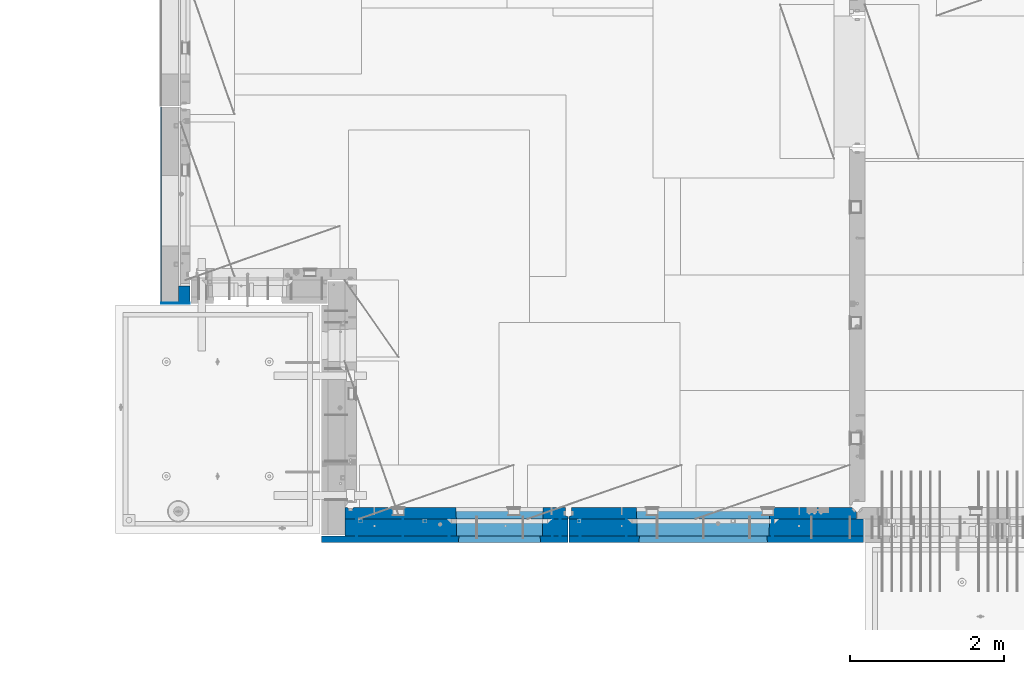
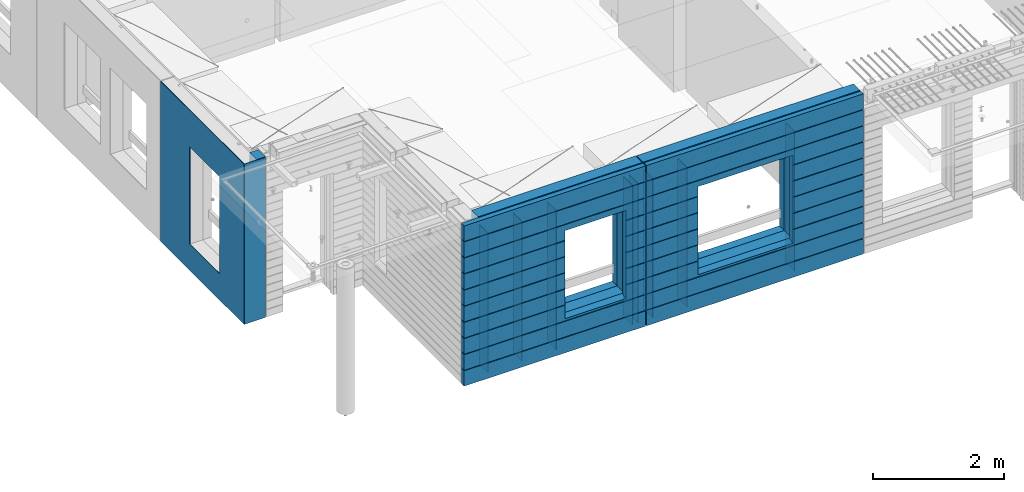
# One storey, part 216 of 334: 17 walls, 3 elements without a shape of their own.
"""IFC2X3 building model written with IfcOpenShell, lengths in millimetres."""

from ifc_helpers import new_model, si_unit, frame, origin_with_axes, place, context, subcontext, project, spatial, faceted_brep, material, type_object, element, aggregate, save


model = new_model("IFC2X3")

# Units and contexts
model_context = context("Model", 3, precision=1e-05, world=origin_with_axes())
body_context = subcontext(model_context, "Body", "Model", "MODEL_VIEW")
ifc_project = project(units=[si_unit("LENGTHUNIT", "METRE", prefix="MILLI"), si_unit("AREAUNIT", "SQUARE_METRE"), si_unit("VOLUMEUNIT", "CUBIC_METRE"), si_unit("MASSUNIT", "GRAM", prefix="KILO"), si_unit("TIMEUNIT", "SECOND"), si_unit("PLANEANGLEUNIT", "RADIAN"), si_unit("SOLIDANGLEUNIT", "STERADIAN"), si_unit("THERMODYNAMICTEMPERATUREUNIT", "DEGREE_CELSIUS"), si_unit("LUMINOUSINTENSITYUNIT", "LUMEN")], contexts=[model_context])

# Site, building, storey
site_placement = place(None, origin_with_axes())
site = spatial("IfcSite", under=ifc_project, at=site_placement, CompositionType="ELEMENT")
building_placement = place(site_placement, origin_with_axes())
building = spatial("IfcBuilding", under=site, at=building_placement, CompositionType="ELEMENT")
storey_placement = place(building_placement, origin_with_axes())
storey = spatial("IfcBuildingStorey", under=building, at=storey_placement, Name="3", CompositionType="ELEMENT", Elevation=0.0)

# Assembly, walls
assembly_1_placement = place(storey_placement, origin_with_axes())
assembly_1 = element("IfcElementAssembly", 1, at=assembly_1_placement, inside=storey, AssemblyPlace="NOTDEFINED", PredefinedType="REINFORCEMENT_UNIT")
ifc_material_1 = material(Name="Undefined")
wall_type_1 = type_object("IfcWallType", PredefinedType="NOTDEFINED")
wall_1_placement = place(assembly_1_placement, frame((10165.0, 7880.0, 89115.0), z_axis=(0.0, 0.0, 1.0), x_axis=(0.0, -1.0, 0.0)))
wall_1 = element("IfcWall", 2, at=wall_1_placement, type_object=wall_type_1, material=ifc_material_1, Name="(PD)", context=body_context, shape_type="Brep", body=[
    faceted_brep([(0.0, 5.0, -1300.0), (0.0, 5.0, 1300.0), (280.0, 5.0, 1300.0), (280.0, 5.0, -1300.0), (0.0, -5.0, 1300.0), (280.0, -5.0, 1300.0), (0.0, -5.0, -1300.0), (280.0, -5.0, -1300.0)], [[[0, 1, 2, 3]], [[1, 4, 5, 2]], [[4, 6, 7, 5]], [[6, 0, 3, 7]], [[5, 7, 3, 2]], [[6, 4, 1, 0]]]),
])
wall_2_placement = place(assembly_1_placement, frame((10765.0, 7880.0, 89115.0), z_axis=(0.0, 0.0, 1.0), x_axis=(0.0, -1.0, 0.0)))
wall_2 = element("IfcWall", 3, at=wall_2_placement, type_object=wall_type_1, material=ifc_material_1, Name="(PD)", context=body_context, shape_type="Brep", body=[
    faceted_brep([(0.0, 5.0, -1300.0), (0.0, 5.0, 1300.0), (280.0, 5.0, 1300.0), (280.0, 5.0, -1300.0), (0.0, -5.0, 1300.0), (280.0, -5.0, 1300.0), (0.0, -5.0, -1300.0), (280.0, -5.0, -1300.0)], [[[0, 1, 2, 3]], [[1, 4, 5, 2]], [[4, 6, 7, 5]], [[6, 0, 3, 7]], [[5, 7, 3, 2]], [[6, 4, 1, 0]]]),
])
wall_3_placement = place(assembly_1_placement, frame((12705.0, 7880.0, 89115.0), z_axis=(0.0, 0.0, 1.0), x_axis=(0.0, -1.0, 0.0)))
wall_3 = element("IfcWall", 4, at=wall_3_placement, type_object=wall_type_1, material=ifc_material_1, Name="(PD)", context=body_context, shape_type="Brep", body=[
    faceted_brep([(0.0, 5.0, -1300.0), (0.0, 5.0, 1300.0), (280.0, 5.0, 1300.0), (280.0, 5.0, -1300.0), (0.0, -5.0, 1300.0), (280.0, -5.0, 1300.0), (0.0, -5.0, -1300.0), (280.0, -5.0, -1300.0)], [[[0, 1, 2, 3]], [[1, 4, 5, 2]], [[4, 6, 7, 5]], [[6, 0, 3, 7]], [[5, 7, 3, 2]], [[6, 4, 1, 0]]]),
])

assembly_2_placement = place(storey_placement, origin_with_axes())
assembly_2 = element("IfcElementAssembly", 5, at=assembly_2_placement, inside=storey, AssemblyPlace="NOTDEFINED", PredefinedType="REINFORCEMENT_UNIT")
wall_4_placement = place(assembly_2_placement, frame((13665.0, 7880.0, 89115.0), z_axis=(0.0, 0.0, 1.0), x_axis=(0.0, -1.0, 0.0)))
wall_4 = element("IfcWall", 6, at=wall_4_placement, type_object=wall_type_1, material=ifc_material_1, Name="(PD)", context=body_context, shape_type="Brep", body=[
    faceted_brep([(0.0, 5.0, -1300.0), (0.0, 5.0, 1300.0), (280.0, 5.0, 1300.0), (280.0, 5.0, -1300.0), (0.0, -5.0, 1300.0), (280.0, -5.0, 1300.0), (0.0, -5.0, -1300.0), (280.0, -5.0, -1300.0)], [[[0, 1, 2, 3]], [[1, 4, 5, 2]], [[4, 6, 7, 5]], [[6, 0, 3, 7]], [[5, 7, 3, 2]], [[6, 4, 1, 0]]]),
])
wall_5_placement = place(assembly_2_placement, frame((13065.0, 7880.0, 89115.0), z_axis=(0.0, 0.0, 1.0), x_axis=(0.0, -1.0, 0.0)))
wall_5 = element("IfcWall", 7, at=wall_5_placement, type_object=wall_type_1, material=ifc_material_1, Name="(PD)", context=body_context, shape_type="Brep", body=[
    faceted_brep([(0.0, 5.0, -1300.0), (0.0, 5.0, 1300.0), (280.0, 5.0, 1300.0), (280.0, 5.0, -1300.0), (0.0, -5.0, 1300.0), (280.0, -5.0, 1300.0), (0.0, -5.0, -1300.0), (280.0, -5.0, -1300.0)], [[[0, 1, 2, 3]], [[1, 4, 5, 2]], [[4, 6, 7, 5]], [[6, 0, 3, 7]], [[5, 7, 3, 2]], [[6, 4, 1, 0]]]),
])
wall_6_placement = place(assembly_2_placement, frame((15565.0, 7880.0, 89115.0), z_axis=(0.0, 0.0, 1.0), x_axis=(0.0, -1.0, 0.0)))
wall_6 = element("IfcWall", 8, at=wall_6_placement, type_object=wall_type_1, material=ifc_material_1, Name="(PD)", context=body_context, shape_type="Brep", body=[
    faceted_brep([(0.0, 5.0, -1300.0), (0.0, 5.0, 1300.0), (280.0, 5.0, 1300.0), (280.0, 5.0, -1300.0), (0.0, -5.0, 1300.0), (280.0, -5.0, 1300.0), (0.0, -5.0, -1300.0), (280.0, -5.0, -1300.0)], [[[0, 1, 2, 3]], [[1, 4, 5, 2]], [[4, 6, 7, 5]], [[6, 0, 3, 7]], [[5, 7, 3, 2]], [[6, 4, 1, 0]]]),
])

# Wall
wall_7_placement = place(assembly_1_placement, frame((12805.0, 7880.0, 89115.0), z_axis=(0.0, 0.0, 1.0), x_axis=(0.0, -1.0, 0.0)))
wall_7 = element("IfcWall", 9, at=wall_7_placement, type_object=wall_type_1, material=ifc_material_1, Name="(PD)", context=body_context, shape_type="Brep", body=[
    faceted_brep([(0.0, 5.0, -1300.0), (0.0, 5.0, 1300.0), (280.0, 5.0, 1300.0), (280.0, 5.0, -1300.0), (0.0, -5.0, 1300.0), (280.0, -5.0, 1300.0), (0.0, -5.0, -1300.0), (280.0, -5.0, -1300.0)], [[[0, 1, 2, 3]], [[1, 4, 5, 2]], [[4, 6, 7, 5]], [[6, 0, 3, 7]], [[5, 7, 3, 2]], [[6, 4, 1, 0]]]),
])

wall_8_placement = place(assembly_1_placement, frame((11365.0, 7880.0, 89115.0), z_axis=(0.0, 0.0, 1.0), x_axis=(0.0, -1.0, 0.0)))
wall_8 = element("IfcWall", 10, at=wall_8_placement, type_object=wall_type_1, material=ifc_material_1, Name="(PD)", context=body_context, shape_type="Brep", body=[
    faceted_brep([(0.0, 5.0, -1300.0), (0.0, 5.0, 1300.0), (280.0, 5.0, 1300.0), (280.0, 5.0, -1300.0), (0.0, -5.0, 1300.0), (280.0, -5.0, 1300.0), (0.0, -5.0, -1300.0), (280.0, -5.0, -1300.0)], [[[0, 1, 2, 3]], [[1, 4, 5, 2]], [[4, 6, 7, 5]], [[6, 0, 3, 7]], [[5, 7, 3, 2]], [[6, 4, 1, 0]]]),
])

# Assembly, wall
assembly_3_placement = place(storey_placement, origin_with_axes())
assembly_3 = element("IfcElementAssembly", 11, at=assembly_3_placement, inside=storey, AssemblyPlace="NOTDEFINED", PredefinedType="REINFORCEMENT_UNIT")
ifc_material_2 = material()
wall_type_2 = type_object("IfcWallType", PredefinedType="NOTDEFINED")
wall_9_placement = place(assembly_3_placement, frame((8000.00051558999, 10765.0000158944, 89247.5), z_axis=(0.0, 0.0, 1.0), x_axis=(-0.999999999997437, -2.26400000064461e-06, 0.0)))
wall_9 = element("IfcWall", 12, at=wall_9_placement, type_object=wall_type_2, material=ifc_material_2, context=body_context, shape_type="Brep", body=[
    faceted_brep([(0.0, 110.0, -1492.5), (0.0, 110.0, 1492.5), (150.000694320282, 109.999999999998, 1492.5), (150.000694320282, 109.999999999998, -1492.5), (0.0, -110.0, 1492.5), (150.000694320282, -110.000000000004, 1492.5), (0.0, -110.0, -1492.5), (150.000694320282, -110.000000000004, -1492.5)], [[[0, 1, 2, 3]], [[1, 4, 5, 2]], [[4, 6, 7, 5]], [[6, 0, 3, 7]], [[5, 7, 3, 2]], [[6, 4, 1, 0]]]),
])

# Wall
ifc_material_3 = material(Name="COS5gt")
wall_10_placement = place(assembly_2_placement, frame((16740.0, 7740.0, 89247.5), z_axis=(0.0, 0.0, 1.0), x_axis=(-1.0, 3.00000001838171e-08, 0.0)))
wall_10 = element("IfcWall", 13, at=wall_10_placement, type_object=wall_type_2, material=ifc_material_3, context=body_context, shape_type="Brep", body=[
    faceted_brep([(0.0, 90.0, 1442.5), (3820.0, 90.0, 1442.5), (3820.0, 110.0, 1442.5), (0.0, 110.0, 1442.5), (0.0, 90.0, 1492.5), (3820.0, 90.0, 1492.5), (0.0, -110.0, 1492.5), (3820.0, -110.0, 1492.5), (3820.0, -110.0, -1492.5), (3820.0, 90.0, -1492.5), (3820.0, 90.0, -1442.5), (3820.0, 110.0, -1442.5), (0.0, 110.0, -1442.5), (0.0, 90.0, -1442.5), (1224.99975425761, 110.0, -807.5), (1254.99975425761, 110.0, -807.5), (2904.99975425761, 110.0, -807.5), (2934.99975425761, 110.0, -807.5), (2934.99975425761, 110.0, -802.5), (2934.99975425761, 110.0, 807.5), (1224.99975425761, 110.0, 807.5), (1224.99975425761, 110.0, -802.5), (1219.05380831167, -110.0, -813.445945945947), (1219.05380831167, -110.0, 813.445945945947), (2940.94570020356, -110.0, -813.445945945947), (2940.94570020356, -110.0, 813.445945945947), (0.0, -110.0, -1492.5), (0.0, 90.0, -1492.5)], [[[0, 1, 2, 3]], [[4, 5, 1, 0]], [[6, 7, 5, 4]], [[2, 1, 5, 7, 8, 9, 10, 11]], [[12, 11, 10, 13]], [[3, 2, 11, 12], [14, 15, 16, 17, 18, 19, 20, 21]], [[22, 14, 21, 20, 23]], [[24, 17, 16, 15, 14, 22]], [[18, 17, 24, 25, 19]], [[23, 20, 19, 25]], [[6, 26, 8, 7], [24, 22, 23, 25]], [[8, 26, 27, 9]], [[13, 10, 9, 27]], [[27, 26, 6, 4, 0, 3, 12, 13]]]),
])

wall_11_placement = place(assembly_1_placement, frame((12912.5, 7740.0, 89247.5), z_axis=(0.0, 0.0, 1.0), x_axis=(-1.0, 3.00000001838171e-08, 0.0)))
wall_11 = element("IfcWall", 14, at=wall_11_placement, type_object=wall_type_2, material=ifc_material_3, context=body_context, shape_type="Brep", body=[
    faceted_brep([(7.5, 90.0, 1442.5), (2897.5, 90.0, 1442.5), (2897.5, 110.0, 1442.5), (7.5, 110.0, 1442.5), (7.5, 90.0, 1492.5), (2897.5, 90.0, 1492.5), (7.5, -110.0, 1492.5), (2897.5, -110.0, 1492.5), (2897.5, -110.0, -1492.5), (2897.5, 90.0, -1492.5), (2897.5, 90.0, -1442.5), (2897.5, 110.0, -1442.5), (7.5, 110.0, -1442.5), (7.5, 90.0, -1442.5), (339.499571152144, 110.0, -807.5), (369.499571152144, 110.0, -807.5), (1419.49957115214, 110.0, -807.5), (1449.49957115214, 110.0, -807.5), (1449.49957115214, 110.0, -802.5), (1449.49957115214, 110.0, 807.5), (339.499571152144, 110.0, 807.5), (339.499571152144, 110.0, -802.5), (333.553625206197, -110.0, -813.445945945947), (333.553625206197, -110.0, 813.445945945947), (1455.44551709809, -110.0, -813.445945945947), (1455.44551709809, -110.0, 813.445945945947), (7.5, -110.0, -1492.5), (7.5, 90.0, -1492.5)], [[[0, 1, 2, 3]], [[4, 5, 1, 0]], [[6, 7, 5, 4]], [[2, 1, 5, 7, 8, 9, 10, 11]], [[12, 11, 10, 13]], [[3, 2, 11, 12], [14, 15, 16, 17, 18, 19, 20, 21]], [[22, 14, 21, 20, 23]], [[24, 17, 16, 15, 14, 22]], [[18, 17, 24, 25, 19]], [[23, 20, 19, 25]], [[6, 26, 8, 7], [24, 22, 23, 25]], [[8, 26, 27, 9]], [[13, 10, 9, 27]], [[26, 6, 4, 0, 3, 12, 13, 27]]]),
])

ifc_material_4 = material(Name="CONCRETE/C30/37")
wall_type_3 = type_object("IfcWallType", PredefinedType="NOTDEFINED")
wall_12_placement = place(assembly_2_placement, frame((16740.0, 7587.5, 89247.5), z_axis=(0.0, 0.0, 1.0), x_axis=(-1.0, 3.00000001838171e-08, 0.0)))
wall_12 = element("IfcWall", 15, at=wall_12_placement, type_object=wall_type_3, material=ifc_material_4, context=body_context, shape_type="Brep", body=[
    faceted_brep([(3820.00000000003, 42.5, 606.999999889245), (3820.00000000002, 32.4999991121731, 605.00000040044), (2913.82328356493, 32.4999991121731, 605.00000040044), (2914.99975425761, 42.5, 606.999999889245), (3820.00000000002, 32.4999992501716, 594.999999999243), (2913.82328358116, 32.4999992501716, 594.999999999243), (3820.00000000003, 42.5, 592.999999944761), (2914.99975425761, 42.5, 592.999999944761), (3820.00000000003, 42.5, 306.999999889245), (2914.99975425761, 42.5, 306.999999889245), (3820.00000000002, 32.4999991121731, 305.00000040044), (2913.82328356493, 32.4999991121731, 305.00000040044), (3820.00000000002, 32.4999992501716, 294.999999999243), (2913.82328358116, 32.4999992501716, 294.999999999243), (3820.00000000003, 42.5, 292.999999944761), (2914.99975425761, 42.5, 292.999999944761), (3820.00000000003, 42.5, 6.99999988924537), (2914.99975425761, 42.5, 6.99999988924537), (3820.00000000003, 32.4999991121731, 5.0000004004396), (2913.82328356493, 32.4999991121731, 5.0000004004396), (3820.00000000003, 32.4999992501716, -5.0000000007567), (2913.82328358116, 32.4999992501716, -5.0000000007567), (3820.00000000003, 42.5, -7.00000005523907), (2914.99975425761, 42.5, -7.00000005523907), (3820.00000000003, 42.5, -293.000000110755), (2914.99975425761, 42.5, -293.000000110755), (3820.00000000003, 32.4999991121731, -294.99999959956), (2913.82328356493, 32.4999991121731, -294.99999959956), (3820.00000000003, 32.4999992501716, -305.000000000757), (2913.82328358116, 32.4999992501716, -305.000000000757), (3820.00000000003, 42.5, -307.000000055239), (2914.99975425761, 42.5, -307.000000055239), (3820.00000000003, 42.5, -593.000000110755), (2914.99975425761, 42.5, -593.000000110755), (3820.00000000003, 32.4999991121731, -594.99999959956), (2913.82328356493, 32.4999991121731, -594.99999959956), (3820.00000000003, 32.4999992501716, -605.000000000757), (2913.82328358116, 32.4999992501716, -605.000000000757), (3820.00000000003, 42.5, -607.000000055239), (2914.99975425761, 42.5, -607.000000055239), (0.0, -42.5, -1492.5), (0.0, 42.5, -1492.5), (3820.00000000003, 42.5, -1492.5), (3820.00000000003, -42.5, -1492.5), (0.0, 42.5, -1207.00000005524), (3820.00000000003, 42.5, -1207.00000005524), (0.0, 32.4999992507037, -1205.00000000074), (3820.00000000003, 32.4999992501716, -1205.00000000076), (0.0, 32.4999991127006, -1194.99999959956), (3820.00000000003, 32.4999991121731, -1194.99999959956), (0.0, 42.5, -1193.00000011075), (3820.00000000003, 42.5, -1193.00000011075), (0.0, 42.5, -907.000000055239), (3820.00000000003, 42.5, -907.000000055239), (0.0, 32.4999992507037, -905.000000000742), (3820.00000000003, 32.4999992501716, -905.000000000757), (0.0, 32.4999991127006, -894.99999959956), (3820.00000000003, 32.4999991121731, -894.99999959956), (0.0, 42.5, -893.000000110755), (3820.00000000003, 42.5, -893.000000110755), (3.63797880709171e-12, 32.4999992507037, 594.999999999258), (3.63797880709171e-12, 32.4999991127006, 605.00000040044), (1246.1762249503, 32.4999991121731, 605.00000040044), (1246.17622493406, 32.4999992501716, 594.999999999243), (0.0, 42.5, 592.999999944761), (1244.99975425761, 42.5, 592.999999944761), (0.0, 42.5, 306.999999889245), (1244.99975425761, 42.5, 306.999999889245), (-3.63797880709171e-12, 32.4999991127006, 305.00000040044), (1246.1762249503, 32.4999991121731, 305.00000040044), (-3.63797880709171e-12, 32.4999992507037, 294.999999999258), (1246.17622493406, 32.4999992501716, 294.999999999243), (0.0, 42.5, 292.999999944761), (1244.99975425761, 42.5, 292.999999944761), (0.0, 42.5, 6.99999988924537), (1244.99975425761, 42.5, 6.99999988924537), (0.0, 32.4999991127006, 5.0000004004396), (1246.1762249503, 32.4999991121731, 5.0000004004396), (0.0, 32.4999992507037, -5.00000000074215), (1246.17622493406, 32.4999992501716, -5.0000000007567), (0.0, 42.5, -7.00000005523907), (1244.99975425761, 42.5, -7.00000005523907), (0.0, 42.5, -293.000000110755), (1244.99975425761, 42.5, -293.000000110755), (0.0, 32.4999991127006, -294.99999959956), (1246.1762249503, 32.4999991121731, -294.99999959956), (0.0, 32.4999992507037, -305.000000000742), (1246.17622493406, 32.4999992501716, -305.000000000757), (0.0, 42.5, -307.000000055239), (1244.99975425761, 42.5, -307.000000055239), (0.0, 42.5, -593.000000110755), (1244.99975425761, 42.5, -593.000000110755), (3.63797880709171e-12, 32.4999991127006, -594.99999959956), (1246.1762249503, 32.4999991121731, -594.99999959956), (3.63797880709171e-12, 32.4999992507037, -605.000000000742), (1246.17622493406, 32.4999992501716, -605.000000000757), (0.0, 42.5, -607.000000055239), (1244.99975425761, 42.5, -607.000000055239), (2914.99975425761, 42.5, -857.5), (1244.99975425761, 42.5, -857.5), (1254.99975425761, -42.5, -807.5), (2904.99975425761, -42.5, -807.5), (2904.99975425761, -42.5, 782.5), (2904.99975425761, -42.5, 787.5), (2914.99975425761, 42.5, 782.5), (1254.99975425761, 42.5, 782.5), (2904.99975425761, 42.5, 782.5), (1254.99975425761, -42.5, 787.5), (1244.99975425761, 42.5, 782.5), (0.0, -42.5, 1492.5), (3820.00000000003, -42.5, 1492.5), (1254.99975425761, -42.5, 782.5), (0.0, 42.5, 1492.5), (3820.00000000003, 42.5, 1492.5), (3820.00000000003, 42.5, 1206.99999988925), (0.0, 42.5, 1206.99999988925), (3820.00000000002, 32.4999991121731, 1205.00000040044), (0.0, 32.4999991127006, 1205.00000040044), (3820.00000000003, 42.5, 892.999999944761), (3820.00000000002, 32.4999992501716, 894.999999999243), (3820.00000000002, 32.4999991121731, 905.00000040044), (3820.00000000003, 42.5, 906.999999889245), (3820.00000000003, 42.5, 1192.99999994476), (3820.00000000002, 32.4999992501716, 1194.99999999924), (0.0, 42.5, 906.999999889245), (0.0, 42.5, 1192.99999994476), (0.0, 32.4999992507037, 1194.99999999926), (0.0, 32.4999991127006, 905.00000040044), (0.0, 32.4999992507037, 894.999999999258), (0.0, 42.5, 892.999999944761), (0.0, 42.5, 606.999999889245), (1244.99975425761, 42.5, 606.999999889245)], [[[0, 1, 2, 3]], [[1, 4, 5, 2]], [[4, 6, 7, 5]], [[6, 8, 9, 7]], [[8, 10, 11, 9]], [[10, 12, 13, 11]], [[12, 14, 15, 13]], [[14, 16, 17, 15]], [[16, 18, 19, 17]], [[18, 20, 21, 19]], [[20, 22, 23, 21]], [[22, 24, 25, 23]], [[24, 26, 27, 25]], [[26, 28, 29, 27]], [[28, 30, 31, 29]], [[30, 32, 33, 31]], [[32, 34, 35, 33]], [[34, 36, 37, 35]], [[36, 38, 39, 37]], [[40, 41, 42, 43]], [[42, 41, 44, 45]], [[46, 47, 45, 44]], [[48, 49, 47, 46]], [[50, 51, 49, 48]], [[51, 50, 52, 53]], [[54, 55, 53, 52]], [[56, 57, 55, 54]], [[58, 59, 57, 56]], [[60, 61, 62, 63]], [[64, 60, 63, 65]], [[66, 64, 65, 67]], [[68, 66, 67, 69]], [[70, 68, 69, 71]], [[72, 70, 71, 73]], [[74, 72, 73, 75]], [[76, 74, 75, 77]], [[78, 76, 77, 79]], [[80, 78, 79, 81]], [[82, 80, 81, 83]], [[84, 82, 83, 85]], [[86, 84, 85, 87]], [[88, 86, 87, 89]], [[90, 88, 89, 91]], [[92, 90, 91, 93]], [[94, 92, 93, 95]], [[96, 94, 95, 97]], [[98, 39, 38, 59, 58, 96, 97, 99]], [[99, 100, 101, 98]], [[102, 103, 104, 3, 2, 5, 7, 9, 11, 13, 15, 17, 19, 21, 23, 25, 27, 29, 31, 33, 35, 37, 39, 98, 101]], [[105, 106, 104, 103, 107, 108]], [[109, 40, 43, 110], [102, 101, 100, 111, 107, 103]], [[112, 109, 110, 113]], [[112, 113, 114, 115]], [[115, 114, 116, 117]], [[113, 110, 43, 42, 45, 47, 49, 51, 53, 55, 57, 59, 38, 36, 34, 32, 30, 28, 26, 24, 22, 20, 18, 16, 14, 12, 10, 8, 6, 4, 1, 0, 118, 119, 120, 121, 122, 123, 116, 114]], [[121, 124, 125, 122]], [[126, 123, 122, 125]], [[117, 116, 123, 126]], [[125, 124, 127, 128, 129, 130, 61, 60, 64, 66, 68, 70, 72, 74, 76, 78, 80, 82, 84, 86, 88, 90, 92, 94, 96, 58, 56, 54, 52, 50, 48, 46, 44, 41, 40, 109, 112, 115, 117, 126]], [[61, 130, 131, 62]], [[108, 107, 111, 100, 99, 97, 95, 93, 91, 89, 87, 85, 83, 81, 79, 77, 75, 73, 71, 69, 67, 65, 63, 62, 131]], [[130, 129, 118, 0, 3, 104, 106, 105, 108, 131]], [[128, 119, 118, 129]], [[127, 120, 119, 128]], [[124, 121, 120, 127]]]),
])

wall_13_placement = place(assembly_1_placement, frame((12912.5, 7587.5, 89247.5), z_axis=(0.0, 0.0, 1.0), x_axis=(-1.0, 3.00000001838171e-08, 0.0)))
wall_13 = element("IfcWall", 16, at=wall_13_placement, type_object=wall_type_3, material=ifc_material_4, context=body_context, shape_type="Brep", body=[
    faceted_brep([(3207.5, -42.5, 1193.0000011433), (3207.5, 42.5, 1192.99999994476), (3197.49999925687, 32.4999992501671, 1194.99999999921), (3197.49999396174, -42.5, 1195.00000105656), (3197.49999368253, -42.5, 1205.00000145777), (3197.49999897767, 32.4999991121604, 1205.00000040043), (3207.5, 42.5, 1206.99999988925), (3207.5, -42.5, 1207.0000010878), (7.4999999999709, -42.5, -1492.5), (7.4999999999709, 42.5, -1492.5), (3207.5, 42.5, -1492.5), (3207.5, -42.5, -1492.5), (7.4999999999709, 42.5, -1207.00000005524), (3207.5, 42.5, -1207.00000005524), (3207.5, -42.5, -1206.9999988567), (3197.49999925687, 32.4999992501671, -1205.00000000079), (3197.49999396174, -42.5, -1204.99999894344), (7.4999999999709, 32.4999992501671, -1205.00000000079), (7.4999999999709, 32.4999991121604, -1194.99999959957), (3197.49999897767, 32.4999991121604, -1194.99999959957), (3197.49999368253, -42.5, -1194.99999854223), (3207.5, -42.5, -1192.9999989122), (3207.5, 42.5, -1193.00000011075), (3207.5, 42.5, -907.000000055239), (3207.5, -42.5, -906.9999988567), (7.4999999999709, 42.5, -1193.00000011075), (7.4999999999709, 42.5, -907.000000055239), (7.4999999999709, 32.4999992501671, -905.000000000786), (3197.49999925687, 32.4999992501671, -905.000000000786), (3197.49999396174, -42.5, -904.999998943444), (3197.49999897767, 32.4999991121604, -894.999999599575), (3197.49999368253, -42.5, -894.999998542233), (7.4999999999709, 32.4999991121604, -894.999999599575), (7.4999999999709, 42.5, -893.000000110755), (3207.5, 42.5, -893.000000110755), (3207.5, -42.5, -892.999998912201), (3207.5, 42.5, -607.000000055239), (3207.5, -42.5, -606.9999988567), (3197.49999925687, 32.4999992501671, -605.000000000786), (3197.49999396174, -42.5, -604.999998943444), (1429.49957115214, 42.5, -607.000000055239), (1428.32310047569, 32.4999992501653, -605.000000000786), (1428.32310045946, 32.4999991121585, -594.999999599575), (3197.49999897767, 32.4999991121604, -594.999999599575), (3197.49999368253, -42.5, -594.999998542233), (3207.5, 42.5, -593.000000110755), (3207.5, -42.5, -592.999998912201), (1429.49957115214, 42.5, -593.000000110755), (3207.5, 42.5, -307.000000055239), (1429.49957115214, 42.5, -307.000000055239), (3207.5, -42.5, -306.9999988567), (3197.49999925687, 32.4999992501671, -305.000000000786), (3197.49999396174, -42.5, -304.999998943444), (1428.32310047569, 32.4999992501653, -305.000000000786), (1428.32310045946, 32.4999991121585, -294.999999599575), (3197.49999897767, 32.4999991121604, -294.999999599575), (3197.49999368253, -42.5, -294.999998542233), (3207.5, 42.5, -293.000000110755), (3207.5, -42.5, -292.999998912201), (1429.49957115214, 42.5, -293.000000110755), (3207.5, 42.5, -7.00000005523907), (1429.49957115214, 42.5, -7.00000005523907), (3207.5, -42.5, -6.99999885669968), (3197.49999925687, 32.4999992501671, -5.0000000007858), (3197.49999396174, -42.5, -4.99999894344364), (1428.32310047569, 32.4999992501653, -5.0000000007858), (1428.32310045946, 32.4999991121585, 5.00000040042505), (3197.49999897767, 32.4999991121604, 5.00000040042505), (3197.49999368253, -42.5, 5.00000145776721), (3207.5, 42.5, 6.99999988924537), (3207.5, -42.5, 7.00000108779932), (1429.49957115214, 42.5, 6.99999988924537), (3207.5, 42.5, 292.999999944761), (1429.49957115214, 42.5, 292.999999944761), (3207.5, -42.5, 293.0000011433), (3197.49999925687, 32.4999992501671, 294.999999999214), (3197.49999396174, -42.5, 295.000001056556), (1428.32310047569, 32.4999992501653, 294.999999999214), (1428.32310045946, 32.4999991121585, 305.000000400425), (3197.49999897767, 32.4999991121604, 305.000000400425), (3197.49999368253, -42.5, 305.000001457767), (3207.5, -42.5, 307.000001087799), (3207.5, 42.5, 306.999999889245), (3207.5, 42.5, 592.999999944761), (3207.5, -42.5, 593.0000011433), (1429.49957115214, 42.5, 306.999999889245), (1429.49957115214, 42.5, 592.999999944761), (1428.32310047569, 32.4999992501653, 594.999999999214), (3197.49999925687, 32.4999992501671, 594.999999999214), (3197.49999396174, -42.5, 595.000001056556), (3197.49999897767, 32.4999991121604, 605.000000400425), (3197.49999368253, -42.5, 605.000001457767), (1428.32310045946, 32.4999991121585, 605.000000400425), (1429.49957115214, 42.5, 606.999999889245), (3207.5, 42.5, 606.999999889245), (3207.5, -42.5, 607.000001087799), (3207.5, 42.5, 892.999999944761), (3207.5, -42.5, 893.0000011433), (3197.49999925687, 32.4999992501671, 894.999999999214), (3197.49999396174, -42.5, 895.000001056556), (7.4999999999709, 42.5, 892.999999944761), (7.49999999998181, 32.4999992501671, 894.999999999214), (7.49999999998181, 32.4999991121604, 905.000000400425), (3197.49999897767, 32.4999991121604, 905.000000400425), (3197.49999368253, -42.5, 905.000001457767), (3207.5, -42.5, 907.000001087799), (3207.5, 42.5, 906.999999889245), (7.4999999999709, 42.5, 906.999999889245), (7.4999999999709, 42.5, 1192.99999994476), (7.49999999998363, 32.4999992501671, 1194.99999999921), (7.4999999999709, 42.5, 1492.5), (7.4999999999709, -42.5, 1492.5), (3207.5, -42.5, 1492.5), (3207.5, 42.5, 1492.5), (7.4999999999709, 42.5, 1206.99999988925), (7.49999999998363, 32.4999991121604, 1205.00000040043), (7.4999999999709, 42.5, 606.999999889245), (7.49999999997999, 32.4999991121604, 605.000000400425), (7.49999999997999, 32.4999992501671, 594.999999999214), (7.4999999999709, 42.5, 592.999999944761), (7.4999999999709, 42.5, 306.999999889245), (7.49999999997453, 32.4999991121604, 305.000000400425), (7.49999999997453, 32.4999992501671, 294.999999999214), (7.4999999999709, 42.5, 292.999999944761), (7.4999999999709, 42.5, 6.99999988924537), (7.4999999999709, 32.4999991121604, 5.00000040042505), (7.4999999999709, 32.4999992501671, -5.0000000007858), (7.4999999999709, 42.5, -7.00000005523907), (7.4999999999709, 42.5, -293.000000110755), (7.4999999999709, 32.4999991121604, -294.999999599575), (7.4999999999709, 32.4999992501671, -305.000000000786), (7.4999999999709, 42.5, -307.000000055239), (7.4999999999709, 42.5, -593.000000110755), (7.49999999996908, 32.4999991121604, -594.999999599575), (7.49999999996908, 32.4999992501671, -605.000000000786), (7.4999999999709, 42.5, -607.000000055239), (360.676041844832, 32.4999991121585, 605.000000400425), (360.676041828596, 32.4999992501653, 594.999999999214), (359.499571152144, 42.5, 592.999999944761), (359.499571152144, 42.5, 306.999999889245), (360.676041844832, 32.4999991121585, 305.000000400425), (360.676041828596, 32.4999992501653, 294.999999999214), (359.499571152144, 42.5, 292.999999944761), (359.499571152144, 42.5, 6.99999988924537), (360.676041844832, 32.4999991121585, 5.00000040042505), (360.676041828596, 32.4999992501653, -5.0000000007858), (359.499571152144, 42.5, -7.00000005523907), (359.499571152144, 42.5, -293.000000110755), (360.676041844832, 32.4999991121585, -294.999999599575), (360.676041828596, 32.4999992501653, -305.000000000786), (359.499571152144, 42.5, -307.000000055239), (359.499571152144, 42.5, -593.000000110755), (360.676041844832, 32.4999991121585, -594.999999599575), (360.676041828596, 32.4999992501653, -605.000000000786), (359.499571152144, 42.5, -607.000000055239), (1429.49957115214, 42.5, -857.5), (359.499571152144, 42.5, -857.5), (369.499571152144, -42.5, -807.5), (1419.49957115214, -42.5, -807.5), (1419.49957115214, -42.5, 782.5), (1419.49957115214, -42.5, 787.5), (1429.49957115214, 42.5, 782.5), (1419.49957115214, 42.5, 782.5), (369.499571152144, 42.5, 782.5), (359.499571152144, 42.5, 782.5), (359.499571152144, 42.5, 606.999999889245), (369.499571152144, -42.5, 787.5), (369.499571152144, -42.5, 782.5)], [[[0, 1, 2, 3]], [[4, 5, 6, 7]], [[3, 2, 5, 4]], [[8, 9, 10, 11]], [[10, 9, 12, 13]], [[11, 10, 13, 14]], [[14, 13, 15, 16]], [[12, 17, 15, 13]], [[17, 18, 19, 15]], [[16, 15, 19, 20]], [[21, 22, 23, 24]], [[20, 19, 22, 21]], [[18, 25, 22, 19]], [[22, 25, 26, 23]], [[26, 27, 28, 23]], [[24, 23, 28, 29]], [[29, 28, 30, 31]], [[27, 32, 30, 28]], [[32, 33, 34, 30]], [[31, 30, 34, 35]], [[35, 34, 36, 37]], [[37, 36, 38, 39]], [[40, 41, 38, 36]], [[41, 42, 43, 38]], [[39, 38, 43, 44]], [[44, 43, 45, 46]], [[42, 47, 45, 43]], [[48, 45, 47, 49]], [[46, 45, 48, 50]], [[50, 48, 51, 52]], [[49, 53, 51, 48]], [[53, 54, 55, 51]], [[52, 51, 55, 56]], [[56, 55, 57, 58]], [[54, 59, 57, 55]], [[60, 57, 59, 61]], [[58, 57, 60, 62]], [[62, 60, 63, 64]], [[61, 65, 63, 60]], [[65, 66, 67, 63]], [[64, 63, 67, 68]], [[68, 67, 69, 70]], [[66, 71, 69, 67]], [[72, 69, 71, 73]], [[70, 69, 72, 74]], [[74, 72, 75, 76]], [[73, 77, 75, 72]], [[77, 78, 79, 75]], [[76, 75, 79, 80]], [[81, 82, 83, 84]], [[80, 79, 82, 81]], [[78, 85, 82, 79]], [[83, 82, 85, 86]], [[86, 87, 88, 83]], [[84, 83, 88, 89]], [[89, 88, 90, 91]], [[87, 92, 90, 88]], [[92, 93, 94, 90]], [[91, 90, 94, 95]], [[95, 94, 96, 97]], [[97, 96, 98, 99]], [[100, 101, 98, 96]], [[101, 102, 103, 98]], [[99, 98, 103, 104]], [[105, 106, 1, 0]], [[104, 103, 106, 105]], [[102, 107, 106, 103]], [[106, 107, 108, 1]], [[108, 109, 2, 1]], [[110, 111, 112, 113]], [[113, 112, 7, 6]], [[110, 113, 6, 114]], [[115, 114, 6, 5]], [[109, 115, 5, 2]], [[108, 107, 102, 101, 100, 116, 117, 118, 119, 120, 121, 122, 123, 124, 125, 126, 127, 128, 129, 130, 131, 132, 133, 134, 135, 33, 32, 27, 26, 25, 18, 17, 12, 9, 8, 111, 110, 114, 115, 109]], [[118, 117, 136, 137]], [[119, 118, 137, 138]], [[120, 119, 138, 139]], [[121, 120, 139, 140]], [[122, 121, 140, 141]], [[123, 122, 141, 142]], [[124, 123, 142, 143]], [[125, 124, 143, 144]], [[126, 125, 144, 145]], [[127, 126, 145, 146]], [[128, 127, 146, 147]], [[129, 128, 147, 148]], [[130, 129, 148, 149]], [[131, 130, 149, 150]], [[132, 131, 150, 151]], [[133, 132, 151, 152]], [[134, 133, 152, 153]], [[135, 134, 153, 154]], [[155, 40, 36, 34, 33, 135, 154, 156]], [[156, 157, 158, 155]], [[159, 160, 161, 93, 92, 87, 86, 85, 78, 77, 73, 71, 66, 65, 61, 59, 54, 53, 49, 47, 42, 41, 40, 155, 158]], [[116, 100, 96, 94, 93, 161, 162, 163, 164, 165]], [[117, 116, 165, 136]], [[164, 166, 167, 157, 156, 154, 153, 152, 151, 150, 149, 148, 147, 146, 145, 144, 143, 142, 141, 140, 139, 138, 137, 136, 165]], [[163, 162, 161, 160, 166, 164]], [[112, 111, 8, 11, 14, 16, 20, 21, 24, 29, 31, 35, 37, 39, 44, 46, 50, 52, 56, 58, 62, 64, 68, 70, 74, 76, 80, 81, 84, 89, 91, 95, 97, 99, 104, 105, 0, 3, 4, 7], [159, 158, 157, 167, 166, 160]]]),
])

ifc_material_5 = material(Name="CONCRETE/C25/30")
wall_type_4 = type_object("IfcWallType", PredefinedType="NOTDEFINED")
wall_14_placement = place(assembly_2_placement, frame((16660.0, 7925.0, 89112.5), z_axis=(0.0, 0.0, 1.0), x_axis=(-1.0, 3.00000001838171e-08, 0.0)))
wall_14 = element("IfcWall", 17, at=wall_14_placement, type_object=wall_type_4, material=ifc_material_5, context=body_context, shape_type="Brep", body=[
    faceted_brep([(10.0, 75.0, 1357.5), (10.0, 75.0, -1357.5), (10.0, -15.0, -1357.5), (10.0, -15.0, 1357.5), (70.0, -75.0, -1357.5), (3740.00000000003, 75.0, -1357.5), (3740.00000000003, 45.0, -1357.5), (3707.5, 32.0, -1357.5), (3707.5, -75.0, -1357.5), (70.0, -75.0, 1357.5), (3740.00000000003, 45.0, 1357.5), (3740.00000000003, 75.0, 1357.5), (3707.5, -75.0, 1357.5), (3707.5, 32.0, 1357.5), (2864.99975425761, -75.0, -682.5), (1134.99975425761, -75.0, -682.5), (1134.99975425761, -75.0, 952.5), (2864.99975425761, -75.0, 952.5), (2860.94570020356, 75.0, -678.445945945947), (1139.05380831167, 75.0, -678.445945945947), (1139.05380831167, 75.0, 948.445945945947), (2860.94570020356, 75.0, 948.445945945947)], [[[0, 1, 2, 3]], [[4, 2, 1, 5, 6, 7, 8]], [[3, 2, 4, 9]], [[10, 11, 0, 3, 9, 12, 13]], [[5, 11, 10, 6]], [[13, 7, 6, 10]], [[12, 8, 7, 13]], [[9, 4, 8, 12], [14, 15, 16, 17]], [[14, 18, 19, 15]], [[15, 19, 20, 16]], [[1, 0, 11, 5], [18, 21, 20, 19]], [[16, 20, 21, 17]], [[18, 14, 17, 21]]]),
])

aggregate(assembly_2, [wall_4, wall_5, wall_6, wall_12, wall_10, wall_14])

wall_15_placement = place(assembly_1_placement, frame((12912.5, 7925.0, 89112.5), z_axis=(0.0, 0.0, 1.0), x_axis=(-1.0, 3.00000001838171e-08, 0.0)))
wall_15 = element("IfcWall", 18, at=wall_15_placement, type_object=wall_type_4, material=ifc_material_5, context=body_context, shape_type="Brep", body=[
    faceted_brep([(2787.5, -75.0, 1357.5), (2787.5, -75.0, -1357.5), (2800.5, -55.0, -1357.5), (2800.5, -55.0, 1357.5), (2852.5, -55.0, 1357.5), (2802.5, -55.0, 1357.5), (2802.5, -55.0, -1357.5), (2852.5, -55.0, -1357.5), (2854.5, -55.0, -1357.5), (2854.5, -55.0, 1357.5), (2867.5, -75.0, -1357.5), (2867.5, -75.0, 1357.5), (2897.5, -75.0, -1357.5), (2897.5, -75.0, 1357.5), (2897.5, 75.0, -1357.5), (2897.5, 75.0, 1357.5), (40.0, -75.0, 1357.5), (7.4999999999709, 75.0, 1357.5), (7.5, 45.0, 1357.5), (40.0, 32.0, 1357.5), (7.4999999999709, 75.0, -1357.5), (7.4999999999709, 45.0, -1357.5), (40.0, 32.0, -1357.5), (40.0, -75.0, -1357.5), (1459.49957115214, -75.0, -682.5), (329.499571152144, -75.0, -682.5), (329.499571152144, -75.0, 952.5), (1459.49957115214, -75.0, 952.5), (1455.44551709809, 75.0, -678.445945945947), (333.553625206197, 75.0, -678.445945945947), (333.553625206197, 75.0, 948.445945945947), (1455.44551709809, 75.0, 948.445945945947)], [[[0, 1, 2, 3]], [[4, 5, 3, 2, 6, 7, 8, 9]], [[9, 8, 10, 11]], [[12, 13, 11, 10]], [[13, 12, 14, 15]], [[16, 0, 3, 5, 4, 9, 11, 13, 15, 17, 18, 19]], [[17, 20, 21, 18]], [[18, 21, 22, 19]], [[20, 14, 12, 10, 8, 7, 6, 2, 1, 23, 22, 21]], [[16, 19, 22, 23]], [[1, 0, 16, 23], [24, 25, 26, 27]], [[24, 28, 29, 25]], [[25, 29, 30, 26]], [[20, 17, 15, 14], [28, 31, 30, 29]], [[26, 30, 31, 27]], [[28, 24, 27, 31]]]),
])

aggregate(assembly_1, [wall_1, wall_2, wall_3, wall_7, wall_8, wall_13, wall_11, wall_15])

wall_type_5 = type_object("IfcWallType", PredefinedType="NOTDEFINED")
wall_16_placement = place(assembly_3_placement, frame((8000.00033490857, 10650.0000304601, 89247.5), z_axis=(0.0, 0.0, 1.0), x_axis=(-1.0, 3.00000001838171e-08, 0.0)))
wall_16 = element("IfcWall", 19, at=wall_16_placement, type_object=wall_type_5, material=ifc_material_4, context=body_context, shape_type="Brep", body=[
    faceted_brep([(0.0, 5.0, -1492.5), (0.0, 5.0, 1492.5), (370.000694320092, 4.99999999999818, 1492.5), (370.000694320092, 4.99999999999818, -1492.5), (0.0, -5.0, 1492.5), (370.000694320092, -5.0, 1492.5), (0.0, -5.0, -1492.5), (370.000694320092, -5.0, -1492.5)], [[[0, 1, 2, 3]], [[1, 4, 5, 2]], [[4, 6, 7, 5]], [[6, 0, 3, 7]], [[5, 7, 3, 2]], [[6, 4, 1, 0]]]),
])

wall_17_placement = place(assembly_3_placement, frame((7625.00002947765, 10874.99966857, 89247.5), z_axis=(0.0, 0.0, 1.0), x_axis=(0.0, 1.0, 0.0)))
wall_17 = element("IfcWall", 20, at=wall_17_placement, type_object=wall_type_5, material=ifc_material_4, context=body_context, shape_type="Brep", body=[
    faceted_brep([(-230.0, -5.0, 1492.5), (-230.0, -5.0, -1492.5), (2320.00069431993, -5.0, -1492.5), (2320.00069431993, -5.0, 1492.5), (520.000578774374, -5.0, -1002.5), (520.000578774374, -5.0, 807.5), (1430.00057877438, -5.0, 807.5), (1430.00057877438, -5.0, -1002.5), (-230.0, 5.0, 1492.5), (2320.00069431993, 5.0, 1492.5), (-230.0, 5.0, -1492.5), (2320.00069431993, 5.0, -1492.5), (520.000578774374, 5.0, -1002.5), (1430.00057877438, 5.0, -1002.5), (1430.00057877438, 5.0, 807.5), (520.000578774374, 5.0, 807.5)], [[[0, 1, 2, 3], [4, 5, 6, 7]], [[8, 0, 3, 9]], [[1, 0, 8, 10]], [[1, 10, 11, 2]], [[3, 2, 11, 9]], [[10, 8, 9, 11], [12, 13, 14, 15]], [[6, 14, 13, 7]], [[5, 15, 14, 6]], [[4, 12, 15, 5]], [[7, 13, 12, 4]]]),
])

aggregate(assembly_3, [wall_16, wall_9, wall_17])

save(model, "model.ifc")
